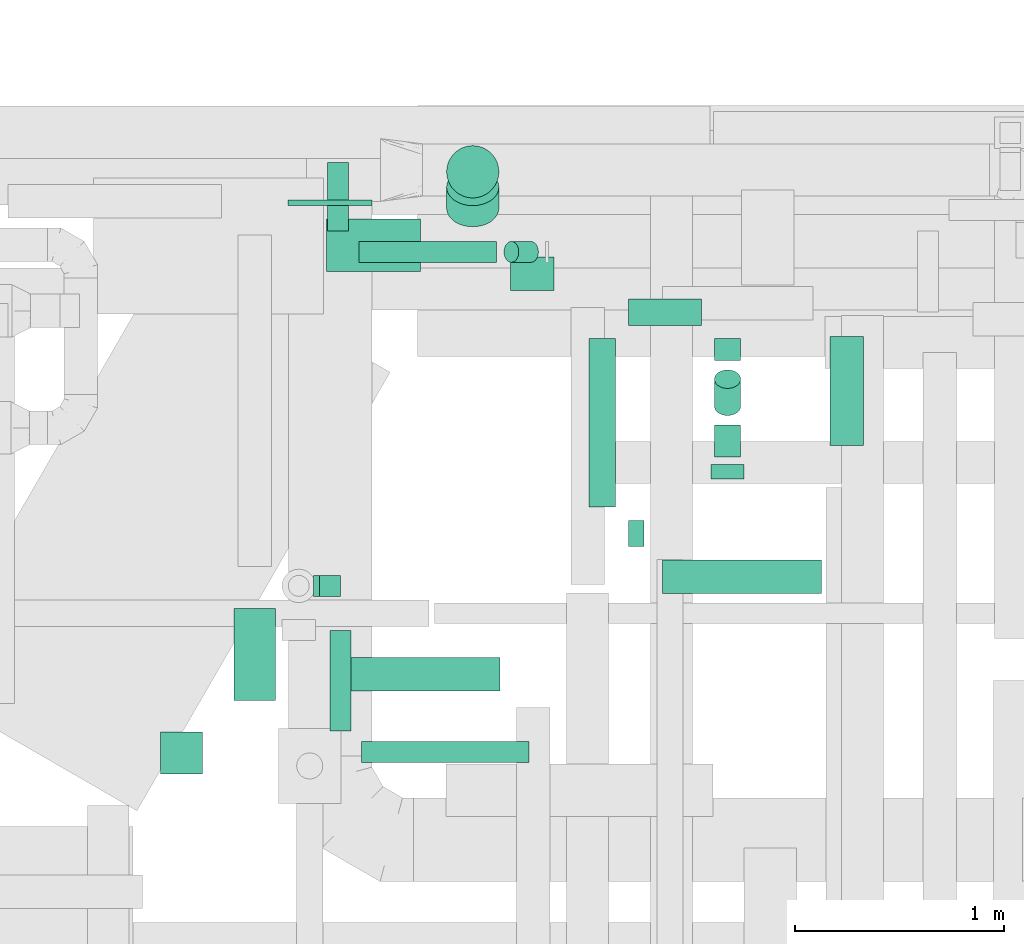
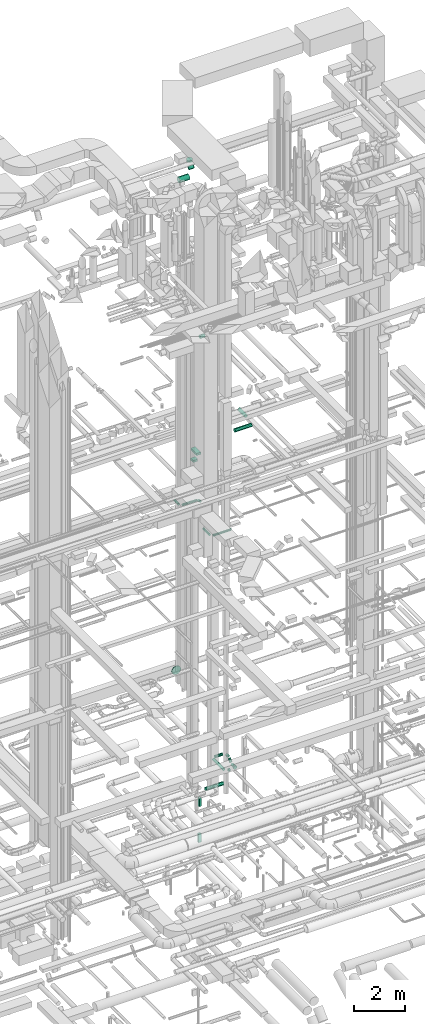
# One storey, part 289 of 337: 23 flow segments, 1 flow fitting.
"""IFC2X3 building model written with IfcOpenShell, lengths in millimetres."""

from ifc_helpers import new_model, entity, si_unit, converted_unit, derived_unit, direction, frame, origin, origin_2d_with_axis, place, context, subcontext, project, spatial, rectangle, circle, extrude, faceted_brep, source, transform, mapped, material, type_object, type_shapes, element, save


model = new_model("IFC2X3")

# Units and contexts
model_context = context("Model", 3, precision=0.01, world=origin(), true_north=direction((6.12303176911189e-17, 1.0)))
body_context = subcontext(model_context, "Body", "Model", "MODEL_VIEW")
ifc_project = project(units=[si_unit("LENGTHUNIT", "METRE", prefix="MILLI"), si_unit("AREAUNIT", "SQUARE_METRE"), si_unit("VOLUMEUNIT", "CUBIC_METRE"), converted_unit("PLANEANGLEUNIT", "DEGREE", entity("IfcRatioMeasure", 0.0174532925199433), si_unit("PLANEANGLEUNIT", "RADIAN"), dimensions=[0, 0, 0, 0, 0, 0, 0]), si_unit("MASSUNIT", "GRAM", prefix="KILO"), derived_unit("MASSDENSITYUNIT", [(si_unit("MASSUNIT", "GRAM", prefix="KILO"), 1), (si_unit("LENGTHUNIT", "METRE"), -3)]), derived_unit("MOMENTOFINERTIAUNIT", [(si_unit("LENGTHUNIT", "METRE"), 4)]), si_unit("TIMEUNIT", "SECOND"), si_unit("FREQUENCYUNIT", "HERTZ"), si_unit("THERMODYNAMICTEMPERATUREUNIT", "DEGREE_CELSIUS"), derived_unit("THERMALTRANSMITTANCEUNIT", [(si_unit("MASSUNIT", "GRAM", prefix="KILO"), 1), (si_unit("THERMODYNAMICTEMPERATUREUNIT", "KELVIN"), -1), (si_unit("TIMEUNIT", "SECOND"), -3)]), derived_unit("VOLUMETRICFLOWRATEUNIT", [(si_unit("LENGTHUNIT", "METRE"), 3), (si_unit("TIMEUNIT", "SECOND"), -1)]), derived_unit("MASSFLOWRATEUNIT", [(si_unit("MASSUNIT", "GRAM", prefix="KILO"), 1), (si_unit("TIMEUNIT", "SECOND"), -1)]), derived_unit("ROTATIONALFREQUENCYUNIT", [(si_unit("TIMEUNIT", "SECOND"), -1)]), si_unit("ELECTRICCURRENTUNIT", "AMPERE"), si_unit("ELECTRICVOLTAGEUNIT", "VOLT"), si_unit("POWERUNIT", "WATT"), si_unit("FORCEUNIT", "NEWTON", prefix="KILO"), si_unit("ILLUMINANCEUNIT", "LUX"), si_unit("LUMINOUSFLUXUNIT", "LUMEN"), si_unit("LUMINOUSINTENSITYUNIT", "CANDELA"), derived_unit("USERDEFINED", [(si_unit("MASSUNIT", "GRAM", prefix="KILO"), -1), (si_unit("LENGTHUNIT", "METRE"), -2), (si_unit("TIMEUNIT", "SECOND"), 3), (si_unit("LUMINOUSFLUXUNIT", "LUMEN"), 1)]), derived_unit("LINEARVELOCITYUNIT", [(si_unit("LENGTHUNIT", "METRE"), 1), (si_unit("TIMEUNIT", "SECOND"), -1)]), si_unit("PRESSUREUNIT", "PASCAL"), derived_unit("USERDEFINED", [(si_unit("LENGTHUNIT", "METRE"), -2), (si_unit("MASSUNIT", "GRAM", prefix="KILO"), 1), (si_unit("TIMEUNIT", "SECOND"), -2)]), derived_unit("LINEARFORCEUNIT", [(si_unit("MASSUNIT", "GRAM", prefix="KILO"), 1), (si_unit("LENGTHUNIT", "METRE"), 1), (si_unit("TIMEUNIT", "SECOND"), -2), (si_unit("LENGTHUNIT", "METRE"), -1)]), derived_unit("PLANARFORCEUNIT", [(si_unit("MASSUNIT", "GRAM", prefix="KILO"), 1), (si_unit("LENGTHUNIT", "METRE"), 1), (si_unit("TIMEUNIT", "SECOND"), -2), (si_unit("LENGTHUNIT", "METRE"), -2)])], contexts=[model_context])

# Site, building, storey
site_placement = place(None, origin())
site = spatial("IfcSite", under=ifc_project, at=site_placement, CompositionType="ELEMENT")
building_placement = place(site_placement, origin())
building = spatial("IfcBuilding", under=site, at=building_placement, CompositionType="ELEMENT")
storey_placement = place(building_placement, origin())
storey = spatial("IfcBuildingStorey", under=building, at=storey_placement, CompositionType="ELEMENT", Elevation=0.0)

# Flow segments
duct_segment_type_1 = type_object("IfcDuctSegmentType", PredefinedType="NOTDEFINED")
flow_segment_1_placement = place(storey_placement, frame((55164.27, 17758.79, -1900.0)))
element("IfcFlowSegment", 1, at=flow_segment_1_placement, inside=storey, type_object=duct_segment_type_1, context=body_context, shape_type="SweptSolid", body=[
    extrude(rectangle(XDim=99.9999999999946, YDim=99.9999999999989, at=origin_2d_with_axis()), frame((50.0, 50.0, 0.0)), (0.0, 0.0, 1.0), 400.0),
])
flow_segment_2_placement = place(storey_placement, frame((55134.27, 17758.79, -3600.0)))
element("IfcFlowSegment", 2, at=flow_segment_2_placement, inside=storey, type_object=duct_segment_type_1, context=body_context, shape_type="SweptSolid", body=[
    extrude(rectangle(XDim=129.999999999996, YDim=99.9999999999989, at=origin_2d_with_axis()), frame((65.0, 50.0, 0.0)), (0.0, 0.0, 1.0), 400.0),
])
flow_segment_3_placement = place(storey_placement, frame((54403.97, 16910.35, 15250.0)))
element("IfcFlowSegment", 3, at=flow_segment_3_placement, inside=storey, type_object=duct_segment_type_1, context=body_context, shape_type="SweptSolid", body=[
    extrude(rectangle(XDim=200.000000000033, YDim=200.0, at=origin_2d_with_axis()), frame((100.0, 100.0, 0.0)), (0.0, 0.0, 1.0), 99.9999999999989),
])
flow_segment_4_placement = place(storey_placement, frame((54753.97, 17260.35, 15250.0)))
element("IfcFlowSegment", 4, at=flow_segment_4_placement, inside=storey, type_object=duct_segment_type_1, context=body_context, shape_type="SweptSolid", body=[
    extrude(rectangle(XDim=440.443970819087, YDim=199.999999999998, at=origin_2d_with_axis()), frame((100.0, 220.22, 0.0), z_axis=(0.0, 0.0, 1.0), x_axis=(0.0, 1.0, 0.0)), (0.0, 0.0, 1.0), 99.9999999999989),
])
duct_segment_type_2 = type_object("IfcDuctSegmentType", PredefinedType="NOTDEFINED")
flow_segment_5_placement = place(storey_placement, frame((56639.42, 17995.84, -914.1)))
element("IfcFlowSegment", 5, at=flow_segment_5_placement, inside=storey, type_object=duct_segment_type_2, context=body_context, shape_type="SweptSolid", body=[
    extrude(circle(Radius=62.5, at=origin_2d_with_axis()), frame((0.0, 64.1, 64.1), z_axis=(1.0, 0.0, 0.0), x_axis=(0.0, 1.0, 0.0)), (0.0, 0.0, 1.0), 73.8914900000245),
])
flow_segment_6_placement = place(storey_placement, frame((56450.32, 18184.93, -914.1)))
element("IfcFlowSegment", 6, at=flow_segment_6_placement, inside=storey, type_object=duct_segment_type_2, context=body_context, shape_type="SweptSolid", body=[
    extrude(circle(Radius=62.5, at=origin_2d_with_axis()), frame((64.1, 0.0, 64.1), z_axis=(0.0, 1.0, 0.0), x_axis=(1.0, 0.0, 0.0)), (0.0, 0.0, 1.0), 806.805240000002),
])
flow_segment_7_placement = place(storey_placement, frame((56639.42, 19052.64, -914.1)))
element("IfcFlowSegment", 7, at=flow_segment_7_placement, inside=storey, type_object=duct_segment_type_2, context=body_context, shape_type="SweptSolid", body=[
    extrude(circle(Radius=62.5, at=origin_2d_with_axis()), frame((0.0, 64.1, 64.1), z_axis=(1.0, 0.0, 0.0), x_axis=(0.0, -1.0, 0.0)), (0.0, 0.0, 1.0), 348.763729999994),
])
flow_segment_8_placement = place(storey_placement, frame((57031.59, 18319.96, -1134.6)))
element("IfcFlowSegment", 8, at=flow_segment_8_placement, inside=storey, type_object=duct_segment_type_2, context=body_context, shape_type="SweptSolid", body=[
    extrude(circle(Radius=80.0, at=origin_2d_with_axis()), frame((81.6, 0.0, 81.6), z_axis=(0.0, 1.0, 0.0), x_axis=(-1.0, 0.0, 0.0)), (0.0, 0.0, 1.0), 68.9999999999995),
])
flow_segment_9_placement = place(storey_placement, frame((57049.09, 18423.96, -1117.1)))
element("IfcFlowSegment", 9, at=flow_segment_9_placement, inside=storey, type_object=duct_segment_type_2, context=body_context, shape_type="SweptSolid", body=[
    extrude(circle(Radius=62.5, at=origin_2d_with_axis()), frame((64.1, 0.0, 64.1), z_axis=(0.0, 1.0, 0.0), x_axis=(-1.0, 0.0, 0.0)), (0.0, 0.0, 1.0), 154.592824703341),
])
flow_segment_10_placement = place(storey_placement, frame((57049.09, 18885.1, -914.1)))
element("IfcFlowSegment", 10, at=flow_segment_10_placement, inside=storey, type_object=duct_segment_type_2, context=body_context, shape_type="SweptSolid", body=[
    extrude(circle(Radius=62.5, at=origin_2d_with_axis()), frame((64.1, 0.0, 64.1), z_axis=(0.0, 1.0, 0.0), x_axis=(1.0, 0.0, 0.0)), (0.0, 0.0, 1.0), 106.634494703398),
])
flow_segment_11_placement = place(storey_placement, frame((57049.09, 18621.15, -1062.18)))
element("IfcFlowSegment", 11, at=flow_segment_11_placement, inside=storey, type_object=duct_segment_type_2, context=body_context, shape_type="SweptSolid", body=[
    extrude(circle(Radius=62.5, at=origin_2d_with_axis()), frame((64.1, 45.79, 45.79), z_axis=(0.0, 0.707106781186546, 0.707106781186549), x_axis=(1.0, 0.0, 0.0)), (0.0, 0.0, 1.0), 183.531962568466),
])
flow_segment_12_placement = place(storey_placement, frame((55224.27, 17305.4, -931.6)))
element("IfcFlowSegment", 12, at=flow_segment_12_placement, inside=storey, type_object=duct_segment_type_2, context=body_context, shape_type="SweptSolid", body=[
    extrude(circle(Radius=80.0, at=origin_2d_with_axis()), frame((0.0, 81.6, 81.6), z_axis=(1.0, 0.0, 0.0), x_axis=(0.0, 1.0, 0.0)), (0.0, 0.0, 1.0), 801.263150000005),
])
flow_segment_13_placement = place(storey_placement, frame((55351.05, 19353.19, 11348.4)))
element("IfcFlowSegment", 13, at=flow_segment_13_placement, inside=storey, type_object=duct_segment_type_2, context=body_context, shape_type="SweptSolid", body=[
    extrude(circle(Radius=50.0, at=origin_2d_with_axis()), frame((0.0, 51.6, 51.6), z_axis=(1.0, 0.0, 0.0), x_axis=(0.0, 1.0, 0.0)), (0.0, 0.0, 1.0), 658.578643762712),
])
flow_segment_14_placement = place(storey_placement, frame((56043.39, 19353.19, 11240.31)))
element("IfcFlowSegment", 14, at=flow_segment_14_placement, inside=storey, type_object=duct_segment_type_2, context=body_context, shape_type="SweptSolid", body=[
    extrude(circle(Radius=50.0, at=origin_2d_with_axis()), frame((36.95, 51.6, 130.4), z_axis=(0.707106781186542, 0.0, -0.707106781186553), x_axis=(0.0, -1.0, 0.0)), (0.0, 0.0, 1.0), 132.157287525428),
])
flow_segment_15_placement = place(storey_placement, frame((55211.75, 17115.6, 11348.4)))
element("IfcFlowSegment", 15, at=flow_segment_15_placement, inside=storey, type_object=duct_segment_type_2, context=body_context, shape_type="SweptSolid", body=[
    extrude(circle(Radius=50.0, at=origin_2d_with_axis()), frame((51.6, 0.0, 51.6), z_axis=(0.0, 1.0, 0.0), x_axis=(-1.0, 0.0, 0.0)), (0.0, 0.0, 1.0), 479.999999999991),
])
flow_segment_16_placement = place(storey_placement, frame((55363.35, 16964.01, 11348.4)))
element("IfcFlowSegment", 16, at=flow_segment_16_placement, inside=storey, type_object=duct_segment_type_2, context=body_context, shape_type="SweptSolid", body=[
    extrude(circle(Radius=50.0, at=origin_2d_with_axis()), frame((0.0, 51.6, 51.6), z_axis=(1.0, 0.0, 0.0), x_axis=(0.0, -1.0, 0.0)), (0.0, 0.0, 1.0), 800.000000000009),
])
flow_segment_17_placement = place(storey_placement, frame((55199.45, 19504.79, 11348.4)))
element("IfcFlowSegment", 17, at=flow_segment_17_placement, inside=storey, type_object=duct_segment_type_2, context=body_context, shape_type="SweptSolid", body=[
    extrude(circle(Radius=50.0, at=origin_2d_with_axis()), frame((51.6, 0.0, 51.6), z_axis=(0.0, 1.0, 0.0), x_axis=(-1.0, 0.0, 0.0)), (0.0, 0.0, 1.0), 326.269796034063),
])
flow_segment_18_placement = place(storey_placement, frame((56075.55, 19218.61, 19118.4)))
element("IfcFlowSegment", 18, at=flow_segment_18_placement, inside=storey, type_object=duct_segment_type_2, context=body_context, shape_type="SweptSolid", body=[
    extrude(circle(Radius=80.0, at=origin_2d_with_axis()), frame((0.0, 81.6, 81.6), z_axis=(1.0, 0.0, 0.0), x_axis=(0.0, 1.0, 0.0)), (0.0, 0.0, 1.0), 208.749999999966),
])
flow_segment_19_placement = place(storey_placement, frame((57601.0, 18479.95, 15293.4)))
element("IfcFlowSegment", 19, at=flow_segment_19_placement, inside=storey, type_object=duct_segment_type_2, context=body_context, shape_type="SweptSolid", body=[
    extrude(circle(Radius=80.0, at=origin_2d_with_axis()), frame((81.6, 0.0, 81.6), z_axis=(0.0, 1.0, 0.0), x_axis=(1.0, 0.0, 0.0)), (0.0, 0.0, 1.0), 520.00000000001),
])
flow_segment_20_placement = place(storey_placement, frame((56802.59, 17770.02, 15293.4)))
element("IfcFlowSegment", 20, at=flow_segment_20_placement, inside=storey, type_object=duct_segment_type_2, context=body_context, shape_type="SweptSolid", body=[
    extrude(circle(Radius=80.0, at=origin_2d_with_axis()), frame((0.0, 81.6, 81.6), z_axis=(1.0, 0.0, 0.0), x_axis=(0.0, 1.0, 0.0)), (0.0, 0.0, 1.0), 759.999999999853),
])
flow_segment_21_placement = place(storey_placement, frame((55195.7, 19309.89, 26760.9)))
element("IfcFlowSegment", 21, at=flow_segment_21_placement, inside=storey, type_object=duct_segment_type_2, context=body_context, shape_type="SweptSolid", body=[
    extrude(circle(Radius=125.0, at=origin_2d_with_axis()), frame((0.0, 126.6, 126.6), z_axis=(1.0, 0.0, 0.0), x_axis=(0.0, 1.0, 0.0)), (0.0, 0.0, 1.0), 450.000000000002),
])
flow_segment_22_placement = place(storey_placement, frame((55769.11, 19523.28, 26974.29)))
element("IfcFlowSegment", 22, at=flow_segment_22_placement, inside=storey, type_object=duct_segment_type_2, context=body_context, shape_type="SweptSolid", body=[
    extrude(circle(Radius=125.0, at=origin_2d_with_axis()), frame((126.6, 89.98, 89.98), z_axis=(0.0, 0.707106781186548, 0.707106781186548), x_axis=(1.0, 0.0, 0.0)), (0.0, 0.0, 1.0), 142.911075500966),
])
flow_segment_23_placement = place(storey_placement, frame((55769.11, 19660.94, 27342.11)))
element("IfcFlowSegment", 23, at=flow_segment_23_placement, inside=storey, type_object=duct_segment_type_2, context=body_context, shape_type="SweptSolid", body=[
    extrude(circle(Radius=125.0, at=origin_2d_with_axis()), frame((126.6, 126.6, 0.0), z_axis=(0.0, 0.0, 1.0), x_axis=(0.0, 1.0, 0.0)), (0.0, 0.0, 1.0), 87.8932188133634),
])

# Flow fitting
ifc_material = material()
duct_fitting_type = type_object("IfcDuctFittingType", PredefinedType="NOTDEFINED", material=ifc_material)
shared_shape = source(origin(), body_context, "Body", "Brep", [
    faceted_brep([(20.0, 200.0, 0.0), (20.0, 194.99, 44.5), (20.0, 180.19, 86.78), (20.0, 156.37, 124.7), (20.0, 124.7, 156.37), (20.0, 86.78, 180.19), (20.0, 44.5, 194.99), (20.0, 0.0, 200.0), (20.0, -44.5, 194.99), (20.0, -86.78, 180.19), (20.0, -124.7, 156.37), (20.0, -156.37, 124.7), (20.0, -180.19, 86.78), (20.0, -194.99, 44.5), (20.0, -200.0, 0.0), (20.0, -194.99, -44.5), (20.0, -180.19, -86.78), (20.0, -156.37, -124.7), (20.0, -124.7, -156.37), (20.0, -86.78, -180.19), (20.0, -44.5, -194.99), (20.0, 0.0, -200.0), (20.0, 44.5, -194.99), (20.0, 86.78, -180.19), (20.0, 124.7, -156.37), (20.0, 156.37, -124.7), (20.0, 180.19, -86.78), (20.0, 194.99, -44.5), (0.0, 0.0, 200.0), (0.0, 30.6, 196.55), (-6.1, 22.25, 197.49), (-6.1, 0.0, 200.0), (0.0, 44.5, 194.99), (-6.1, 44.5, 194.99), (0.0, 65.64, 187.59), (0.0, 86.78, 180.19), (-6.1, 65.64, 187.59), (-6.1, 86.78, 180.19), (0.0, 105.74, 168.28), (0.0, 124.7, 156.37), (-6.1, 105.74, 168.28), (-6.1, 124.7, 156.37), (0.0, 140.53, 140.53), (0.0, 156.37, 124.7), (-6.1, 140.53, 140.53), (-6.1, 156.37, 124.7), (0.0, 168.28, 105.74), (0.0, 180.19, 86.78), (-6.1, 168.28, 105.74), (-6.1, 180.19, 86.78), (0.0, 187.59, 65.64), (0.0, 194.99, 44.5), (-6.1, 187.59, 65.64), (-6.1, 194.99, 44.5), (0.0, 197.49, 22.25), (0.0, 200.0, 0.0), (-6.1, 200.0, 0.0), (-6.1, 196.55, 30.6), (0.0, 196.55, -30.6), (-6.1, 197.49, -22.25), (0.0, 194.99, -44.5), (-6.1, 194.99, -44.5), (0.0, 187.59, -65.64), (0.0, 180.19, -86.78), (-6.1, 187.59, -65.64), (-6.1, 180.19, -86.78), (0.0, 168.28, -105.74), (0.0, 156.37, -124.7), (-6.1, 168.28, -105.74), (-6.1, 156.37, -124.7), (0.0, 140.53, -140.53), (0.0, 124.7, -156.37), (-6.1, 140.53, -140.53), (-6.1, 124.7, -156.37), (0.0, 105.74, -168.28), (0.0, 86.78, -180.19), (-6.1, 86.78, -180.19), (-6.1, 105.74, -168.28), (0.0, 44.5, -194.99), (0.0, 65.64, -187.59), (-6.1, 44.5, -194.99), (-6.1, 65.64, -187.59), (0.0, 0.0, -200.0), (0.0, 30.6, -196.55), (-6.1, 22.25, -197.49), (-6.1, 0.0, -200.0), (0.0, -30.6, -196.55), (-6.1, -22.25, -197.49), (0.0, -44.5, -194.99), (-6.1, -44.5, -194.99), (0.0, -65.64, -187.59), (0.0, -86.78, -180.19), (-6.1, -65.64, -187.59), (-6.1, -86.78, -180.19), (0.0, -105.74, -168.28), (0.0, -124.7, -156.37), (-6.1, -105.74, -168.28), (-6.1, -124.7, -156.37), (0.0, -140.53, -140.53), (0.0, -156.37, -124.7), (-6.1, -140.53, -140.53), (-6.1, -156.37, -124.7), (0.0, -168.28, -105.74), (0.0, -180.19, -86.78), (-6.1, -168.28, -105.74), (-6.1, -180.19, -86.78), (0.0, -194.99, -44.5), (0.0, -196.55, -30.6), (0.0, -200.0, 0.0), (-6.1, -197.49, -22.25), (-6.1, -200.0, 0.0), (-6.1, -194.99, -44.5), (0.0, -187.59, -65.64), (-6.1, -187.59, -65.64), (0.0, -196.55, 30.6), (-6.1, -197.49, 22.25), (0.0, -194.99, 44.5), (-6.1, -194.99, 44.5), (0.0, -187.59, 65.64), (0.0, -180.19, 86.78), (-6.1, -187.59, 65.64), (-6.1, -180.19, 86.78), (0.0, -168.28, 105.74), (0.0, -156.37, 124.7), (-6.1, -168.28, 105.74), (-6.1, -156.37, 124.7), (0.0, -140.53, 140.53), (0.0, -124.7, 156.37), (-6.1, -140.53, 140.53), (-6.1, -124.7, 156.37), (0.0, -105.74, 168.28), (0.0, -86.78, 180.19), (-6.1, -105.74, 168.28), (-6.1, -86.78, 180.19), (0.0, -65.64, 187.59), (0.0, -44.5, 194.99), (-6.1, -65.64, 187.59), (-6.1, -44.5, 194.99), (0.0, -22.25, 197.49), (-6.1, -30.6, 196.55)], [[[0, 1, 2, 3, 4, 5, 6, 7, 8, 9, 10, 11, 12, 13, 14, 15, 16, 17, 18, 19, 20, 21, 22, 23, 24, 25, 26, 27]], [[28, 7, 6]], [[6, 29, 28]], [[28, 29, 30]], [[31, 28, 30]], [[6, 32, 29]], [[32, 33, 29]], [[29, 33, 30]], [[6, 5, 32]], [[5, 34, 32]], [[5, 35, 34]], [[36, 34, 35]], [[35, 37, 36]], [[33, 34, 36]], [[34, 33, 32]], [[4, 35, 5]], [[4, 38, 35]], [[4, 39, 38]], [[38, 39, 40]], [[39, 41, 40]], [[37, 38, 40]], [[38, 37, 35]], [[4, 3, 39]], [[3, 42, 39]], [[3, 43, 42]], [[44, 42, 43]], [[43, 45, 44]], [[41, 42, 44]], [[39, 42, 41]], [[43, 3, 2]], [[2, 46, 43]], [[45, 43, 46]], [[2, 47, 46]], [[47, 48, 46]], [[47, 49, 48]], [[45, 46, 48]], [[2, 1, 47]], [[1, 50, 47]], [[1, 51, 50]], [[52, 50, 51]], [[51, 53, 52]], [[49, 50, 52]], [[50, 49, 47]], [[0, 51, 1]], [[0, 54, 51]], [[0, 55, 54]], [[55, 56, 54]], [[56, 57, 54]], [[57, 51, 54]], [[51, 57, 53]], [[55, 0, 27]], [[27, 58, 55]], [[55, 58, 59]], [[56, 55, 59]], [[27, 60, 58]], [[60, 61, 58]], [[58, 61, 59]], [[27, 26, 60]], [[26, 62, 60]], [[26, 63, 62]], [[64, 62, 63]], [[63, 65, 64]], [[61, 62, 64]], [[62, 61, 60]], [[25, 63, 26]], [[25, 66, 63]], [[25, 67, 66]], [[66, 67, 68]], [[67, 69, 68]], [[65, 66, 68]], [[66, 65, 63]], [[25, 24, 67]], [[24, 70, 67]], [[24, 71, 70]], [[72, 70, 71]], [[71, 73, 72]], [[69, 70, 72]], [[67, 70, 69]], [[24, 23, 71]], [[23, 74, 71]], [[23, 75, 74]], [[74, 75, 76]], [[76, 77, 74]], [[73, 74, 77]], [[73, 71, 74]], [[23, 22, 78]], [[23, 78, 79]], [[23, 79, 75]], [[79, 78, 80]], [[79, 80, 81]], [[81, 75, 79]], [[75, 81, 76]], [[82, 22, 21]], [[22, 82, 83]], [[82, 84, 83]], [[82, 85, 84]], [[80, 83, 84]], [[83, 80, 78]], [[22, 83, 78]], [[82, 21, 20]], [[20, 86, 82]], [[82, 86, 87]], [[85, 82, 87]], [[20, 88, 86]], [[88, 89, 86]], [[86, 89, 87]], [[20, 19, 88]], [[19, 90, 88]], [[19, 91, 90]], [[92, 90, 91]], [[91, 93, 92]], [[89, 90, 92]], [[90, 89, 88]], [[18, 91, 19]], [[18, 94, 91]], [[18, 95, 94]], [[94, 95, 96]], [[95, 97, 96]], [[93, 94, 96]], [[94, 93, 91]], [[18, 17, 95]], [[17, 98, 95]], [[17, 99, 98]], [[100, 98, 99]], [[99, 101, 100]], [[97, 98, 100]], [[95, 98, 97]], [[17, 16, 99]], [[16, 102, 99]], [[16, 103, 102]], [[103, 104, 102]], [[103, 105, 104]], [[101, 102, 104]], [[101, 99, 102]], [[15, 14, 106]], [[14, 107, 106]], [[14, 108, 107]], [[108, 109, 107]], [[108, 110, 109]], [[111, 107, 109]], [[107, 111, 106]], [[16, 15, 106]], [[16, 106, 112]], [[16, 112, 103]], [[112, 106, 111]], [[112, 111, 113]], [[103, 113, 105]], [[113, 103, 112]], [[108, 14, 13]], [[13, 114, 108]], [[108, 114, 115]], [[110, 108, 115]], [[13, 116, 114]], [[116, 117, 114]], [[114, 117, 115]], [[13, 12, 116]], [[12, 118, 116]], [[12, 119, 118]], [[120, 118, 119]], [[119, 121, 120]], [[117, 118, 120]], [[118, 117, 116]], [[11, 119, 12]], [[11, 122, 119]], [[11, 123, 122]], [[122, 123, 124]], [[123, 125, 124]], [[121, 122, 124]], [[122, 121, 119]], [[11, 10, 123]], [[10, 126, 123]], [[10, 127, 126]], [[128, 126, 127]], [[127, 129, 128]], [[125, 126, 128]], [[123, 126, 125]], [[127, 10, 9]], [[9, 130, 127]], [[129, 127, 130]], [[9, 131, 130]], [[131, 132, 130]], [[131, 133, 132]], [[129, 130, 132]], [[9, 8, 131]], [[8, 134, 131]], [[8, 135, 134]], [[136, 134, 135]], [[135, 137, 136]], [[133, 134, 136]], [[134, 133, 131]], [[7, 135, 8]], [[7, 138, 135]], [[7, 28, 138]], [[28, 31, 138]], [[31, 139, 138]], [[139, 135, 138]], [[135, 139, 137]], [[87, 89, 92, 93, 96, 97, 100, 101, 104, 105, 113, 111, 109, 110, 115, 117, 120, 121, 124, 125, 128, 129, 132, 133, 136, 137, 139, 31, 30, 33, 36, 37, 40, 41, 44, 45, 48, 49, 52, 53, 57, 56, 59, 61, 64, 65, 68, 69, 72, 73, 77, 76, 81, 80, 84, 85]]]),
])
type_shapes(duct_fitting_type, [shared_shape])
flow_fitting_placement = place(storey_placement, frame((55213.74, 19646.24, 3450.0), z_axis=(0.0, 0.0, -1.0), x_axis=(0.0, -1.0, 0.0)))
element("IfcFlowFitting", 24, at=flow_fitting_placement, inside=storey, type_object=duct_fitting_type, material=ifc_material, context=body_context, shape_type="MappedRepresentation", body=[
    mapped(shared_shape, transform((0.0, 0.0, 0.0), scale=1.0)),
])

save(model, "model.ifc")
